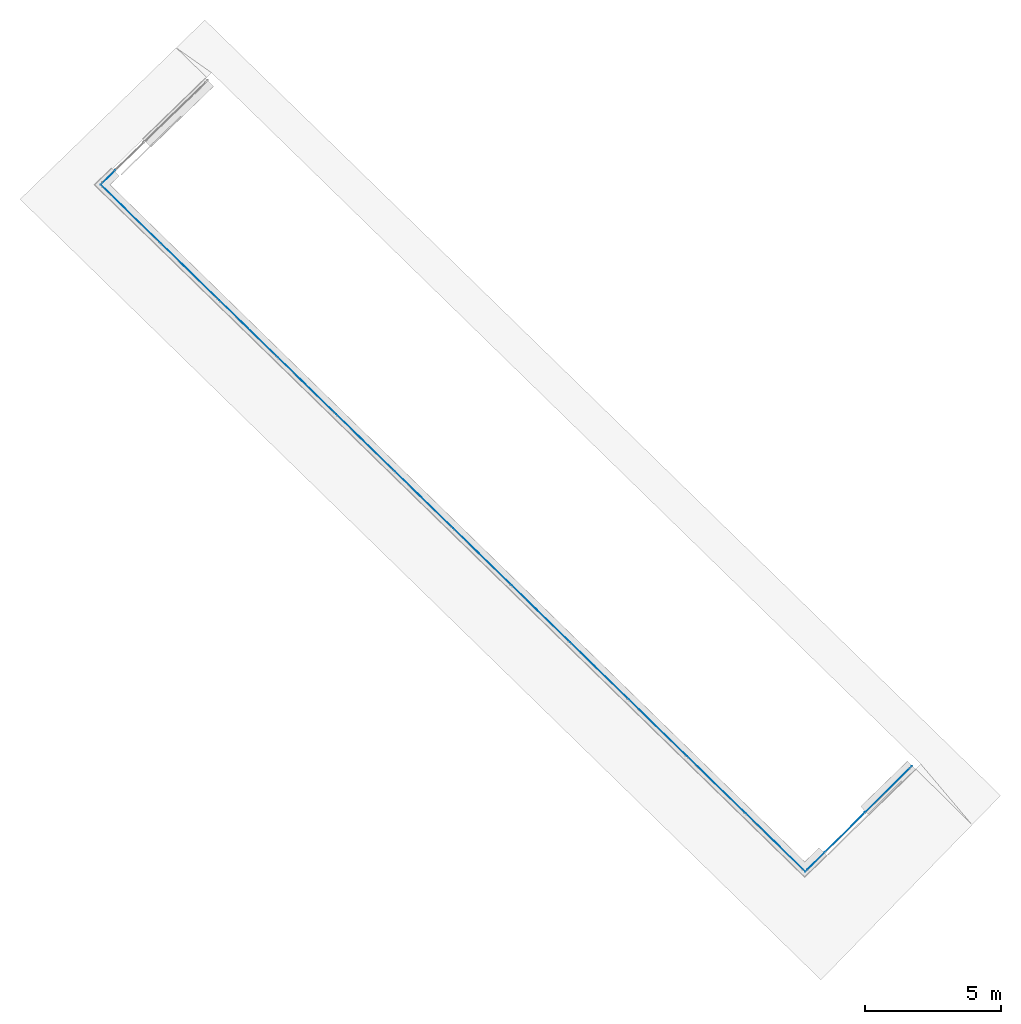
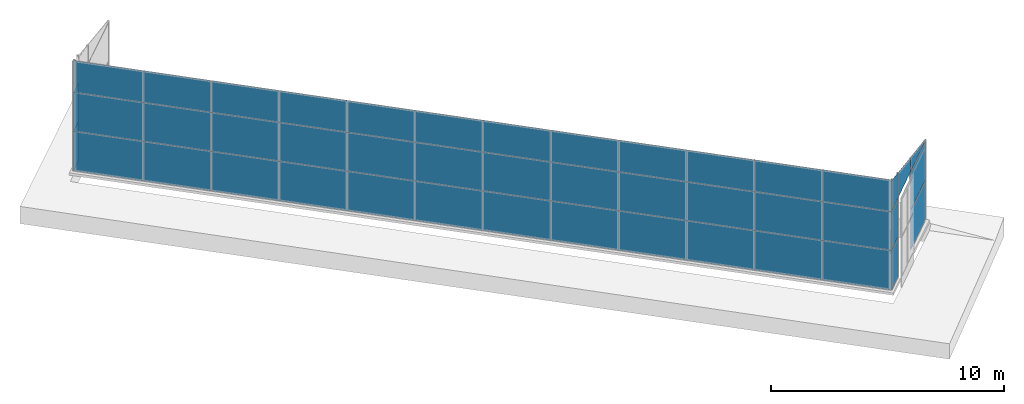
# One storey, part 9 of 13: 45 plates, 3 elements without a shape of their own.
"""IFC4 building model written with IfcOpenShell, lengths in metres."""

from ifc_helpers import new_model, entity, si_unit, converted_unit, direction, frame, origin, place, context, subcontext, project, spatial, indexed_curve, outline, extrude, source, transform, mapped, material, type_object, type_shapes, element, aggregate, save


model = new_model("IFC4")

# Units and contexts
model_context = context("Model", 3, precision=1e-05, world=origin(), true_north=direction((6.123233995736766e-17, 1.0)))
body_context = subcontext(model_context, "Body", "Model", "MODEL_VIEW")
ifc_project = project(units=[si_unit("LENGTHUNIT", "METRE"), si_unit("AREAUNIT", "SQUARE_METRE"), si_unit("VOLUMEUNIT", "CUBIC_METRE"), converted_unit("PLANEANGLEUNIT", "DEGREE", entity("IfcPlaneAngleMeasure", 0.017453292519943278), si_unit("PLANEANGLEUNIT", "RADIAN"), dimensions=[0, 0, 0, 0, 0, 0, 0])], contexts=[model_context])

# Site, building, storey
site_placement = place(None, frame((0.0, 0.0, 0.0), z_axis=(0.0, 0.0, 1.0), x_axis=(0.7160934825303189, -0.6980043870045516, 0.0)))
site = spatial("IfcSite", under=ifc_project, at=site_placement, CompositionType="ELEMENT")
building_placement = place(site_placement, origin())
building = spatial("IfcBuilding", under=site, at=building_placement, CompositionType="ELEMENT")
storey_placement = place(building_placement, frame((0.0, 0.0, -7.0)))
storey = spatial("IfcBuildingStorey", under=building, at=storey_placement, Name="-7.00 m", CompositionType="ELEMENT", Elevation=-7.000000000000001)

# Curtain wall, plates
curtain_wall_type_1 = type_object("IfcCurtainWallType", Name="Facciata continua:Vetrata_2", PredefinedType="NOTDEFINED")
curtain_wall_1_placement = place(storey_placement, frame((0.0, 0.0, 7.0)))
curtain_wall_1 = element("IfcCurtainWall", 1, at=curtain_wall_1_placement, inside=storey, type_object=curtain_wall_type_1, Name="Facciata continua:Vetrata_2", ObjectType="Facciata continua:Vetrata_2", PredefinedType="NOTDEFINED")
ifc_material = material(Name="Default - Vetro", Category="Vetro")
plate_type_1 = type_object("IfcPlateType", Name="Pannello sistema:Vetrato_fine", PredefinedType="CURTAIN_PANEL", material=ifc_material)
shared_shape_1 = source(origin(), body_context, "Body", "SweptSolid", [
    extrude(outline(indexed_curve([(-0.0025, -1.541372928393129), (0.0025, -1.541372928393129), (0.0025, 1.541372928393129), (-0.0025, 1.541372928393129), (-0.0025, -1.541372928393129)], self_intersect=False)), frame((0.0, 0.0, 0.0), z_axis=(0.0, 0.0, 1.0), x_axis=(0.0, 1.0, 0.0)), (0.0, 0.0, 1.0), 2.0800000000000005),
])
type_shapes(plate_type_1, [shared_shape_1])
plate_1_placement = place(curtain_wall_1_placement, frame((-26.27233328426332, -6.97785437653578, -6.94)))
plate_1 = element("IfcPlate", 2, at=plate_1_placement, type_object=plate_type_1, material=ifc_material, Name="Pannello sistema:Vetrato_fine", ObjectType="Pannello sistema:Vetrato_fine", PredefinedType="CURTAIN_PANEL", context=body_context, shape_type="MappedRepresentation", body=[
    mapped(shared_shape_1, transform((0.0, 0.0, 0.0), scale=1.0)),
])
plate_type_2 = type_object("IfcPlateType", Name="Pannello sistema:Vetrato_fine", PredefinedType="CURTAIN_PANEL", material=ifc_material)
shared_shape_2 = source(origin(), body_context, "Body", "SweptSolid", [
    extrude(outline(indexed_curve([(-0.0025, -1.500587508215072), (0.0025, -1.500587508215072), (0.0025, 1.500587508215072), (-0.0025, 1.500587508215072), (-0.0025, -1.500587508215072)], self_intersect=False)), frame((0.0, 0.0, 0.0), z_axis=(0.0, 0.0, 1.0), x_axis=(0.0, 1.0, 0.0)), (0.0, 0.0, 1.0), 2.0800000000000005),
])
type_shapes(plate_type_2, [shared_shape_2])
plate_2_placement = place(curtain_wall_1_placement, frame((-23.23037284765512, -6.977854376535789, -6.94)))
plate_2 = element("IfcPlate", 3, at=plate_2_placement, type_object=plate_type_2, material=ifc_material, Name="Pannello sistema:Vetrato_fine", ObjectType="Pannello sistema:Vetrato_fine", PredefinedType="CURTAIN_PANEL", context=body_context, shape_type="MappedRepresentation", body=[
    mapped(shared_shape_2, transform((0.0, 0.0, 0.0), scale=1.0)),
])
plate_3_placement = place(curtain_wall_1_placement, frame((-20.229197831224973, -6.977854376535799, -6.94)))
plate_3 = element("IfcPlate", 4, at=plate_3_placement, type_object=plate_type_2, material=ifc_material, Name="Pannello sistema:Vetrato_fine", ObjectType="Pannello sistema:Vetrato_fine", PredefinedType="CURTAIN_PANEL", context=body_context, shape_type="MappedRepresentation", body=[
    mapped(shared_shape_2, transform((0.0, 0.0, 0.0), scale=1.0)),
])
plate_4_placement = place(curtain_wall_1_placement, frame((-17.22802281479483, -6.9778543765358085, -6.94)))
plate_4 = element("IfcPlate", 5, at=plate_4_placement, type_object=plate_type_2, material=ifc_material, Name="Pannello sistema:Vetrato_fine", ObjectType="Pannello sistema:Vetrato_fine", PredefinedType="CURTAIN_PANEL", context=body_context, shape_type="MappedRepresentation", body=[
    mapped(shared_shape_2, transform((0.0, 0.0, 0.0), scale=1.0)),
])
plate_5_placement = place(curtain_wall_1_placement, frame((-14.226847798364687, -6.977854376535818, -6.94)))
plate_5 = element("IfcPlate", 6, at=plate_5_placement, type_object=plate_type_2, material=ifc_material, Name="Pannello sistema:Vetrato_fine", ObjectType="Pannello sistema:Vetrato_fine", PredefinedType="CURTAIN_PANEL", context=body_context, shape_type="MappedRepresentation", body=[
    mapped(shared_shape_2, transform((0.0, 0.0, 0.0), scale=1.0)),
])
plate_6_placement = place(curtain_wall_1_placement, frame((-11.225672781934538, -6.977854376535828, -6.94)))
plate_6 = element("IfcPlate", 7, at=plate_6_placement, type_object=plate_type_2, material=ifc_material, Name="Pannello sistema:Vetrato_fine", ObjectType="Pannello sistema:Vetrato_fine", PredefinedType="CURTAIN_PANEL", context=body_context, shape_type="MappedRepresentation", body=[
    mapped(shared_shape_2, transform((0.0, 0.0, 0.0), scale=1.0)),
])
plate_7_placement = place(curtain_wall_1_placement, frame((-8.22449776550439, -6.977854376535838, -6.94)))
plate_7 = element("IfcPlate", 8, at=plate_7_placement, type_object=plate_type_2, material=ifc_material, Name="Pannello sistema:Vetrato_fine", ObjectType="Pannello sistema:Vetrato_fine", PredefinedType="CURTAIN_PANEL", context=body_context, shape_type="MappedRepresentation", body=[
    mapped(shared_shape_2, transform((0.0, 0.0, 0.0), scale=1.0)),
])
plate_8_placement = place(curtain_wall_1_placement, frame((-5.223322749074251, -6.977854376535847, -6.94)))
plate_8 = element("IfcPlate", 9, at=plate_8_placement, type_object=plate_type_2, material=ifc_material, Name="Pannello sistema:Vetrato_fine", ObjectType="Pannello sistema:Vetrato_fine", PredefinedType="CURTAIN_PANEL", context=body_context, shape_type="MappedRepresentation", body=[
    mapped(shared_shape_2, transform((0.0, 0.0, 0.0), scale=1.0)),
])
plate_9_placement = place(curtain_wall_1_placement, frame((-2.2221477326441077, -6.9778543765358565, -6.94)))
plate_9 = element("IfcPlate", 10, at=plate_9_placement, type_object=plate_type_2, material=ifc_material, Name="Pannello sistema:Vetrato_fine", ObjectType="Pannello sistema:Vetrato_fine", PredefinedType="CURTAIN_PANEL", context=body_context, shape_type="MappedRepresentation", body=[
    mapped(shared_shape_2, transform((0.0, 0.0, 0.0), scale=1.0)),
])
plate_10_placement = place(curtain_wall_1_placement, frame((0.779027283786036, -6.977854376535866, -6.94)))
plate_10 = element("IfcPlate", 11, at=plate_10_placement, type_object=plate_type_2, material=ifc_material, Name="Pannello sistema:Vetrato_fine", ObjectType="Pannello sistema:Vetrato_fine", PredefinedType="CURTAIN_PANEL", context=body_context, shape_type="MappedRepresentation", body=[
    mapped(shared_shape_2, transform((0.0, 0.0, 0.0), scale=1.0)),
])
plate_11_placement = place(curtain_wall_1_placement, frame((3.7802023002161795, -6.977854376535876, -6.94)))
plate_11 = element("IfcPlate", 12, at=plate_11_placement, type_object=plate_type_2, material=ifc_material, Name="Pannello sistema:Vetrato_fine", ObjectType="Pannello sistema:Vetrato_fine", PredefinedType="CURTAIN_PANEL", context=body_context, shape_type="MappedRepresentation", body=[
    mapped(shared_shape_2, transform((0.0, 0.0, 0.0), scale=1.0)),
])
plate_type_3 = type_object("IfcPlateType", Name="Pannello sistema:Vetrato_fine", PredefinedType="CURTAIN_PANEL", material=ifc_material)
shared_shape_3 = source(origin(), body_context, "Body", "SweptSolid", [
    extrude(outline(indexed_curve([(-0.0025, -1.530587508215076), (0.0025, -1.530587508215076), (0.0025, 1.530587508215076), (-0.0025, 1.530587508215076), (-0.0025, -1.530587508215076)], self_intersect=False)), frame((0.0, 0.0, 0.0), z_axis=(0.0, 0.0, 1.0), x_axis=(0.0, 1.0, 0.0)), (0.0, 0.0, 1.0), 2.0800000000000005),
])
type_shapes(plate_type_3, [shared_shape_3])
plate_12_placement = place(curtain_wall_1_placement, frame((6.81137731664633, -6.977854376535886, -6.94)))
plate_12 = element("IfcPlate", 13, at=plate_12_placement, type_object=plate_type_3, material=ifc_material, Name="Pannello sistema:Vetrato_fine", ObjectType="Pannello sistema:Vetrato_fine", PredefinedType="CURTAIN_PANEL", context=body_context, shape_type="MappedRepresentation", body=[
    mapped(shared_shape_3, transform((0.0, 0.0, 0.0), scale=1.0)),
])
plate_type_4 = type_object("IfcPlateType", Name="Pannello sistema:Vetrato_fine", PredefinedType="CURTAIN_PANEL", material=ifc_material)
shared_shape_4 = source(origin(), body_context, "Body", "SweptSolid", [
    extrude(outline(indexed_curve([(-0.0025, -1.541372928393129), (0.0025, -1.541372928393129), (0.0025, 1.541372928393129), (-0.0025, 1.541372928393129), (-0.0025, -1.541372928393129)], self_intersect=False)), frame((0.0, 0.0, 0.0), z_axis=(0.0, 0.0, 1.0), x_axis=(0.0, 1.0, 0.0)), (0.0, 0.0, 1.0), 2.030000000000001),
])
type_shapes(plate_type_4, [shared_shape_4])
plate_13_placement = place(curtain_wall_1_placement, frame((-26.27233328426332, -6.97785437653578, -4.86)))
plate_13 = element("IfcPlate", 14, at=plate_13_placement, type_object=plate_type_4, material=ifc_material, Name="Pannello sistema:Vetrato_fine", ObjectType="Pannello sistema:Vetrato_fine", PredefinedType="CURTAIN_PANEL", context=body_context, shape_type="MappedRepresentation", body=[
    mapped(shared_shape_4, transform((0.0, 0.0, 0.0), scale=1.0)),
])
plate_type_5 = type_object("IfcPlateType", Name="Pannello sistema:Vetrato_fine", PredefinedType="CURTAIN_PANEL", material=ifc_material)
shared_shape_5 = source(origin(), body_context, "Body", "SweptSolid", [
    extrude(outline(indexed_curve([(-0.0025, -1.500587508215072), (0.0025, -1.500587508215072), (0.0025, 1.500587508215072), (-0.0025, 1.500587508215072), (-0.0025, -1.500587508215072)], self_intersect=False)), frame((0.0, 0.0, 0.0), z_axis=(0.0, 0.0, 1.0), x_axis=(0.0, 1.0, 0.0)), (0.0, 0.0, 1.0), 2.030000000000001),
])
type_shapes(plate_type_5, [shared_shape_5])
plate_14_placement = place(curtain_wall_1_placement, frame((-23.23037284765512, -6.977854376535789, -4.86)))
plate_14 = element("IfcPlate", 15, at=plate_14_placement, type_object=plate_type_5, material=ifc_material, Name="Pannello sistema:Vetrato_fine", ObjectType="Pannello sistema:Vetrato_fine", PredefinedType="CURTAIN_PANEL", context=body_context, shape_type="MappedRepresentation", body=[
    mapped(shared_shape_5, transform((0.0, 0.0, 0.0), scale=1.0)),
])
plate_15_placement = place(curtain_wall_1_placement, frame((-20.229197831224973, -6.977854376535799, -4.86)))
plate_15 = element("IfcPlate", 16, at=plate_15_placement, type_object=plate_type_5, material=ifc_material, Name="Pannello sistema:Vetrato_fine", ObjectType="Pannello sistema:Vetrato_fine", PredefinedType="CURTAIN_PANEL", context=body_context, shape_type="MappedRepresentation", body=[
    mapped(shared_shape_5, transform((0.0, 0.0, 0.0), scale=1.0)),
])
plate_16_placement = place(curtain_wall_1_placement, frame((-17.22802281479483, -6.9778543765358085, -4.86)))
plate_16 = element("IfcPlate", 17, at=plate_16_placement, type_object=plate_type_5, material=ifc_material, Name="Pannello sistema:Vetrato_fine", ObjectType="Pannello sistema:Vetrato_fine", PredefinedType="CURTAIN_PANEL", context=body_context, shape_type="MappedRepresentation", body=[
    mapped(shared_shape_5, transform((0.0, 0.0, 0.0), scale=1.0)),
])
plate_17_placement = place(curtain_wall_1_placement, frame((-14.226847798364687, -6.977854376535818, -4.86)))
plate_17 = element("IfcPlate", 18, at=plate_17_placement, type_object=plate_type_5, material=ifc_material, Name="Pannello sistema:Vetrato_fine", ObjectType="Pannello sistema:Vetrato_fine", PredefinedType="CURTAIN_PANEL", context=body_context, shape_type="MappedRepresentation", body=[
    mapped(shared_shape_5, transform((0.0, 0.0, 0.0), scale=1.0)),
])
plate_18_placement = place(curtain_wall_1_placement, frame((-11.225672781934538, -6.977854376535828, -4.86)))
plate_18 = element("IfcPlate", 19, at=plate_18_placement, type_object=plate_type_5, material=ifc_material, Name="Pannello sistema:Vetrato_fine", ObjectType="Pannello sistema:Vetrato_fine", PredefinedType="CURTAIN_PANEL", context=body_context, shape_type="MappedRepresentation", body=[
    mapped(shared_shape_5, transform((0.0, 0.0, 0.0), scale=1.0)),
])
plate_19_placement = place(curtain_wall_1_placement, frame((-8.22449776550439, -6.977854376535838, -4.86)))
plate_19 = element("IfcPlate", 20, at=plate_19_placement, type_object=plate_type_5, material=ifc_material, Name="Pannello sistema:Vetrato_fine", ObjectType="Pannello sistema:Vetrato_fine", PredefinedType="CURTAIN_PANEL", context=body_context, shape_type="MappedRepresentation", body=[
    mapped(shared_shape_5, transform((0.0, 0.0, 0.0), scale=1.0)),
])
plate_20_placement = place(curtain_wall_1_placement, frame((-5.223322749074251, -6.977854376535847, -4.86)))
plate_20 = element("IfcPlate", 21, at=plate_20_placement, type_object=plate_type_5, material=ifc_material, Name="Pannello sistema:Vetrato_fine", ObjectType="Pannello sistema:Vetrato_fine", PredefinedType="CURTAIN_PANEL", context=body_context, shape_type="MappedRepresentation", body=[
    mapped(shared_shape_5, transform((0.0, 0.0, 0.0), scale=1.0)),
])
plate_21_placement = place(curtain_wall_1_placement, frame((-2.2221477326441077, -6.9778543765358565, -4.86)))
plate_21 = element("IfcPlate", 22, at=plate_21_placement, type_object=plate_type_5, material=ifc_material, Name="Pannello sistema:Vetrato_fine", ObjectType="Pannello sistema:Vetrato_fine", PredefinedType="CURTAIN_PANEL", context=body_context, shape_type="MappedRepresentation", body=[
    mapped(shared_shape_5, transform((0.0, 0.0, 0.0), scale=1.0)),
])
plate_22_placement = place(curtain_wall_1_placement, frame((0.779027283786036, -6.977854376535866, -4.86)))
plate_22 = element("IfcPlate", 23, at=plate_22_placement, type_object=plate_type_5, material=ifc_material, Name="Pannello sistema:Vetrato_fine", ObjectType="Pannello sistema:Vetrato_fine", PredefinedType="CURTAIN_PANEL", context=body_context, shape_type="MappedRepresentation", body=[
    mapped(shared_shape_5, transform((0.0, 0.0, 0.0), scale=1.0)),
])
plate_23_placement = place(curtain_wall_1_placement, frame((3.7802023002161795, -6.977854376535876, -4.86)))
plate_23 = element("IfcPlate", 24, at=plate_23_placement, type_object=plate_type_5, material=ifc_material, Name="Pannello sistema:Vetrato_fine", ObjectType="Pannello sistema:Vetrato_fine", PredefinedType="CURTAIN_PANEL", context=body_context, shape_type="MappedRepresentation", body=[
    mapped(shared_shape_5, transform((0.0, 0.0, 0.0), scale=1.0)),
])
plate_type_6 = type_object("IfcPlateType", Name="Pannello sistema:Vetrato_fine", PredefinedType="CURTAIN_PANEL", material=ifc_material)
shared_shape_6 = source(origin(), body_context, "Body", "SweptSolid", [
    extrude(outline(indexed_curve([(-0.0025, -1.5305875082150737), (0.0025, -1.5305875082150737), (0.0025, 1.5305875082150737), (-0.0025, 1.5305875082150737), (-0.0025, -1.5305875082150737)], self_intersect=False)), frame((0.0, 0.0, 0.0), z_axis=(0.0, 0.0, 1.0), x_axis=(0.0, 1.0, 0.0)), (0.0, 0.0, 1.0), 2.030000000000001),
])
type_shapes(plate_type_6, [shared_shape_6])
plate_24_placement = place(curtain_wall_1_placement, frame((6.811377316646325, -6.977854376535886, -4.86)))
plate_24 = element("IfcPlate", 25, at=plate_24_placement, type_object=plate_type_6, material=ifc_material, Name="Pannello sistema:Vetrato_fine", ObjectType="Pannello sistema:Vetrato_fine", PredefinedType="CURTAIN_PANEL", context=body_context, shape_type="MappedRepresentation", body=[
    mapped(shared_shape_6, transform((0.0, 0.0, 0.0), scale=1.0)),
])
plate_type_7 = type_object("IfcPlateType", Name="Pannello sistema:Vetrato_fine", PredefinedType="CURTAIN_PANEL", material=ifc_material)
shared_shape_7 = source(origin(), body_context, "Body", "SweptSolid", [
    extrude(outline(indexed_curve([(-0.0025, -1.541372928393129), (0.0025, -1.541372928393129), (0.0025, 1.541372928393129), (-0.0025, 1.541372928393129), (-0.0025, -1.541372928393129)], self_intersect=False)), frame((0.0, 0.0, 0.0), z_axis=(0.0, 0.0, 1.0), x_axis=(0.0, 1.0, 0.0)), (0.0, 0.0, 1.0), 1.6699999999999993),
])
type_shapes(plate_type_7, [shared_shape_7])
plate_25_placement = place(curtain_wall_1_placement, frame((-26.27233328426332, -6.97785437653578, -2.829999999999999)))
plate_25 = element("IfcPlate", 26, at=plate_25_placement, type_object=plate_type_7, material=ifc_material, Name="Pannello sistema:Vetrato_fine", ObjectType="Pannello sistema:Vetrato_fine", PredefinedType="CURTAIN_PANEL", context=body_context, shape_type="MappedRepresentation", body=[
    mapped(shared_shape_7, transform((0.0, 0.0, 0.0), scale=1.0)),
])
plate_type_8 = type_object("IfcPlateType", Name="Pannello sistema:Vetrato_fine", PredefinedType="CURTAIN_PANEL", material=ifc_material)
shared_shape_8 = source(origin(), body_context, "Body", "SweptSolid", [
    extrude(outline(indexed_curve([(-0.0025, -1.500587508215072), (0.0025, -1.500587508215072), (0.0025, 1.500587508215072), (-0.0025, 1.500587508215072), (-0.0025, -1.500587508215072)], self_intersect=False)), frame((0.0, 0.0, 0.0), z_axis=(0.0, 0.0, 1.0), x_axis=(0.0, 1.0, 0.0)), (0.0, 0.0, 1.0), 1.6699999999999993),
])
type_shapes(plate_type_8, [shared_shape_8])
plate_26_placement = place(curtain_wall_1_placement, frame((-23.23037284765512, -6.977854376535789, -2.829999999999999)))
plate_26 = element("IfcPlate", 27, at=plate_26_placement, type_object=plate_type_8, material=ifc_material, Name="Pannello sistema:Vetrato_fine", ObjectType="Pannello sistema:Vetrato_fine", PredefinedType="CURTAIN_PANEL", context=body_context, shape_type="MappedRepresentation", body=[
    mapped(shared_shape_8, transform((0.0, 0.0, 0.0), scale=1.0)),
])
plate_27_placement = place(curtain_wall_1_placement, frame((-20.229197831224973, -6.977854376535799, -2.829999999999999)))
plate_27 = element("IfcPlate", 28, at=plate_27_placement, type_object=plate_type_8, material=ifc_material, Name="Pannello sistema:Vetrato_fine", ObjectType="Pannello sistema:Vetrato_fine", PredefinedType="CURTAIN_PANEL", context=body_context, shape_type="MappedRepresentation", body=[
    mapped(shared_shape_8, transform((0.0, 0.0, 0.0), scale=1.0)),
])
plate_28_placement = place(curtain_wall_1_placement, frame((-17.22802281479483, -6.9778543765358085, -2.829999999999999)))
plate_28 = element("IfcPlate", 29, at=plate_28_placement, type_object=plate_type_8, material=ifc_material, Name="Pannello sistema:Vetrato_fine", ObjectType="Pannello sistema:Vetrato_fine", PredefinedType="CURTAIN_PANEL", context=body_context, shape_type="MappedRepresentation", body=[
    mapped(shared_shape_8, transform((0.0, 0.0, 0.0), scale=1.0)),
])
plate_29_placement = place(curtain_wall_1_placement, frame((-14.226847798364687, -6.977854376535818, -2.829999999999999)))
plate_29 = element("IfcPlate", 30, at=plate_29_placement, type_object=plate_type_8, material=ifc_material, Name="Pannello sistema:Vetrato_fine", ObjectType="Pannello sistema:Vetrato_fine", PredefinedType="CURTAIN_PANEL", context=body_context, shape_type="MappedRepresentation", body=[
    mapped(shared_shape_8, transform((0.0, 0.0, 0.0), scale=1.0)),
])
plate_30_placement = place(curtain_wall_1_placement, frame((-11.225672781934538, -6.977854376535828, -2.829999999999999)))
plate_30 = element("IfcPlate", 31, at=plate_30_placement, type_object=plate_type_8, material=ifc_material, Name="Pannello sistema:Vetrato_fine", ObjectType="Pannello sistema:Vetrato_fine", PredefinedType="CURTAIN_PANEL", context=body_context, shape_type="MappedRepresentation", body=[
    mapped(shared_shape_8, transform((0.0, 0.0, 0.0), scale=1.0)),
])
plate_31_placement = place(curtain_wall_1_placement, frame((-8.22449776550439, -6.977854376535838, -2.829999999999999)))
plate_31 = element("IfcPlate", 32, at=plate_31_placement, type_object=plate_type_8, material=ifc_material, Name="Pannello sistema:Vetrato_fine", ObjectType="Pannello sistema:Vetrato_fine", PredefinedType="CURTAIN_PANEL", context=body_context, shape_type="MappedRepresentation", body=[
    mapped(shared_shape_8, transform((0.0, 0.0, 0.0), scale=1.0)),
])
plate_32_placement = place(curtain_wall_1_placement, frame((-5.223322749074251, -6.977854376535847, -2.829999999999999)))
plate_32 = element("IfcPlate", 33, at=plate_32_placement, type_object=plate_type_8, material=ifc_material, Name="Pannello sistema:Vetrato_fine", ObjectType="Pannello sistema:Vetrato_fine", PredefinedType="CURTAIN_PANEL", context=body_context, shape_type="MappedRepresentation", body=[
    mapped(shared_shape_8, transform((0.0, 0.0, 0.0), scale=1.0)),
])
plate_33_placement = place(curtain_wall_1_placement, frame((-2.2221477326441077, -6.9778543765358565, -2.829999999999999)))
plate_33 = element("IfcPlate", 34, at=plate_33_placement, type_object=plate_type_8, material=ifc_material, Name="Pannello sistema:Vetrato_fine", ObjectType="Pannello sistema:Vetrato_fine", PredefinedType="CURTAIN_PANEL", context=body_context, shape_type="MappedRepresentation", body=[
    mapped(shared_shape_8, transform((0.0, 0.0, 0.0), scale=1.0)),
])
plate_34_placement = place(curtain_wall_1_placement, frame((0.779027283786036, -6.977854376535866, -2.829999999999999)))
plate_34 = element("IfcPlate", 35, at=plate_34_placement, type_object=plate_type_8, material=ifc_material, Name="Pannello sistema:Vetrato_fine", ObjectType="Pannello sistema:Vetrato_fine", PredefinedType="CURTAIN_PANEL", context=body_context, shape_type="MappedRepresentation", body=[
    mapped(shared_shape_8, transform((0.0, 0.0, 0.0), scale=1.0)),
])
plate_35_placement = place(curtain_wall_1_placement, frame((3.7802023002161795, -6.977854376535876, -2.829999999999999)))
plate_35 = element("IfcPlate", 36, at=plate_35_placement, type_object=plate_type_8, material=ifc_material, Name="Pannello sistema:Vetrato_fine", ObjectType="Pannello sistema:Vetrato_fine", PredefinedType="CURTAIN_PANEL", context=body_context, shape_type="MappedRepresentation", body=[
    mapped(shared_shape_8, transform((0.0, 0.0, 0.0), scale=1.0)),
])
plate_type_9 = type_object("IfcPlateType", Name="Pannello sistema:Vetrato_fine", PredefinedType="CURTAIN_PANEL", material=ifc_material)
shared_shape_9 = source(origin(), body_context, "Body", "SweptSolid", [
    extrude(outline(indexed_curve([(-0.0025, -1.5305875082150737), (0.0025, -1.5305875082150737), (0.0025, 1.5305875082150737), (-0.0025, 1.5305875082150737), (-0.0025, -1.5305875082150737)], self_intersect=False)), frame((0.0, 0.0, 0.0), z_axis=(0.0, 0.0, 1.0), x_axis=(0.0, 1.0, 0.0)), (0.0, 0.0, 1.0), 1.6699999999999993),
])
type_shapes(plate_type_9, [shared_shape_9])
plate_36_placement = place(curtain_wall_1_placement, frame((6.811377316646325, -6.977854376535886, -2.829999999999999)))
plate_36 = element("IfcPlate", 37, at=plate_36_placement, type_object=plate_type_9, material=ifc_material, Name="Pannello sistema:Vetrato_fine", ObjectType="Pannello sistema:Vetrato_fine", PredefinedType="CURTAIN_PANEL", context=body_context, shape_type="MappedRepresentation", body=[
    mapped(shared_shape_9, transform((0.0, 0.0, 0.0), scale=1.0)),
])
aggregate(curtain_wall_1, [plate_1, plate_2, plate_3, plate_4, plate_5, plate_6, plate_7, plate_8, plate_9, plate_10, plate_11, plate_12, plate_13, plate_14, plate_15, plate_16, plate_17, plate_18, plate_19, plate_20, plate_21, plate_22, plate_23, plate_24, plate_25, plate_26, plate_27, plate_28, plate_29, plate_30, plate_31, plate_32, plate_33, plate_34, plate_35, plate_36])

curtain_wall_type_2 = type_object("IfcCurtainWallType", Name="Facciata continua:Vetrata_1", PredefinedType="NOTDEFINED")
curtain_wall_2_placement = place(storey_placement, frame((0.0, 0.0, 7.0)))
curtain_wall_2 = element("IfcCurtainWall", 38, at=curtain_wall_2_placement, inside=storey, type_object=curtain_wall_type_2, Name="Facciata continua:Vetrata_1", ObjectType="Facciata continua:Vetrata_1", PredefinedType="NOTDEFINED")
plate_type_10 = type_object("IfcPlateType", Name="Pannello sistema:Vetrato_fine", PredefinedType="CURTAIN_PANEL", material=ifc_material)
shared_shape_10 = source(origin(), body_context, "Body", "SweptSolid", [
    extrude(outline(indexed_curve([(-0.0025, -0.5028489241452144), (0.0025, -0.5028489241452144), (0.0025, 0.5028489241452144), (-0.0025, 0.5028489241452144), (-0.0025, -0.5028489241452144)], self_intersect=False)), frame((0.0, 0.0, 0.0), z_axis=(0.0, 0.0, 1.0), x_axis=(0.0, 1.0, 0.0)), (0.0, 0.0, 1.0), 2.0800000000000005),
])
type_shapes(plate_type_10, [shared_shape_10])
plate_37_placement = place(curtain_wall_2_placement, frame((8.350833160124862, -6.475083660260913, -6.94), z_axis=(0.0, 0.0, 1.0), x_axis=(0.017636182236115534, 0.9998444704433458, 0.0)))
plate_37 = element("IfcPlate", 39, at=plate_37_placement, type_object=plate_type_10, material=ifc_material, Name="Pannello sistema:Vetrato_fine", ObjectType="Pannello sistema:Vetrato_fine", PredefinedType="CURTAIN_PANEL", context=body_context, shape_type="MappedRepresentation", body=[
    mapped(shared_shape_10, transform((0.0, 0.0, 0.0), scale=1.0)),
])
plate_type_11 = type_object("IfcPlateType", Name="Pannello sistema:Vetrato_fine", PredefinedType="CURTAIN_PANEL", material=ifc_material)
shared_shape_11 = source(origin(), body_context, "Body", "SweptSolid", [
    extrude(outline(indexed_curve([(-0.0025, -1.2125762929908375), (0.0025, -1.2125762929908375), (0.0025, 1.2125762929908375), (-0.0025, 1.2125762929908375), (-0.0025, -1.2125762929908375)], self_intersect=False)), frame((0.0, 0.0, 0.0), z_axis=(0.0, 0.0, 1.0), x_axis=(0.0, 1.0, 0.0)), (0.0, 0.0, 1.0), 2.0800000000000005),
])
type_shapes(plate_type_11, [shared_shape_11])
plate_38_placement = place(curtain_wall_2_placement, frame((8.417713793361655, -2.683433606621964, -6.94), z_axis=(0.0, 0.0, 1.0), x_axis=(0.017636182236115534, 0.9998444704433458, 0.0)))
plate_38 = element("IfcPlate", 40, at=plate_38_placement, type_object=plate_type_11, material=ifc_material, Name="Pannello sistema:Vetrato_fine", ObjectType="Pannello sistema:Vetrato_fine", PredefinedType="CURTAIN_PANEL", context=body_context, shape_type="MappedRepresentation", body=[
    mapped(shared_shape_11, transform((0.0, 0.0, 0.0), scale=1.0)),
])
plate_type_12 = type_object("IfcPlateType", Name="Pannello sistema:Vetrato_fine", PredefinedType="CURTAIN_PANEL", material=ifc_material)
shared_shape_12 = source(origin(), body_context, "Body", "SweptSolid", [
    extrude(outline(indexed_curve([(-0.0025, -0.5028489241452144), (0.0025, -0.5028489241452144), (0.0025, 0.5028489241452144), (-0.0025, 0.5028489241452144), (-0.0025, -0.5028489241452144)], self_intersect=False)), frame((0.0, 0.0, 0.0), z_axis=(0.0, 0.0, 1.0), x_axis=(0.0, 1.0, 0.0)), (0.0, 0.0, 1.0), 2.030000000000001),
])
type_shapes(plate_type_12, [shared_shape_12])
plate_39_placement = place(curtain_wall_2_placement, frame((8.350833160124862, -6.475083660260913, -4.86), z_axis=(0.0, 0.0, 1.0), x_axis=(0.017636182236115534, 0.9998444704433458, 0.0)))
plate_39 = element("IfcPlate", 41, at=plate_39_placement, type_object=plate_type_12, material=ifc_material, Name="Pannello sistema:Vetrato_fine", ObjectType="Pannello sistema:Vetrato_fine", PredefinedType="CURTAIN_PANEL", context=body_context, shape_type="MappedRepresentation", body=[
    mapped(shared_shape_12, transform((0.0, 0.0, 0.0), scale=1.0)),
])
plate_type_13 = type_object("IfcPlateType", Name="Pannello sistema:Vetrato_fine", PredefinedType="CURTAIN_PANEL", material=ifc_material)
shared_shape_13 = source(origin(), body_context, "Body", "SweptSolid", [
    extrude(outline(indexed_curve([(-0.0025, -1.2125762929908375), (0.0025, -1.2125762929908375), (0.0025, 1.2125762929908375), (-0.0025, 1.2125762929908375), (-0.0025, -1.2125762929908375)], self_intersect=False)), frame((0.0, 0.0, 0.0), z_axis=(0.0, 0.0, 1.0), x_axis=(0.0, 1.0, 0.0)), (0.0, 0.0, 1.0), 2.030000000000001),
])
type_shapes(plate_type_13, [shared_shape_13])
plate_40_placement = place(curtain_wall_2_placement, frame((8.417713793361655, -2.683433606621964, -4.86), z_axis=(0.0, 0.0, 1.0), x_axis=(0.017636182236115534, 0.9998444704433458, 0.0)))
plate_40 = element("IfcPlate", 42, at=plate_40_placement, type_object=plate_type_13, material=ifc_material, Name="Pannello sistema:Vetrato_fine", ObjectType="Pannello sistema:Vetrato_fine", PredefinedType="CURTAIN_PANEL", context=body_context, shape_type="MappedRepresentation", body=[
    mapped(shared_shape_13, transform((0.0, 0.0, 0.0), scale=1.0)),
])
plate_type_14 = type_object("IfcPlateType", Name="Pannello sistema:Vetrato_fine", PredefinedType="CURTAIN_PANEL", material=ifc_material)
shared_shape_14 = source(origin(), body_context, "Body", "SweptSolid", [
    extrude(outline(indexed_curve([(-0.9029179157321354, -0.42023724237480276), (0.6870820842678648, -0.42023724237480276), (0.6870820842678713, -0.33044672708164685), (0.43167166292853454, 0.5854606059156261), (-0.9029179157321354, 0.5854606059156261), (-0.9029179157321354, -0.42023724237480276)], self_intersect=False)), frame((-0.08261168177041169, -0.0025000000000009476, 0.9029179157321354), z_axis=(0.0, 1.0, 0.0), x_axis=(0.0, 0.0, 1.0)), (0.0, 0.0, 1.0), 0.005),
])
type_shapes(plate_type_14, [shared_shape_14])
plate_41_placement = place(curtain_wall_2_placement, frame((8.350833160124862, -6.475083660260913, -2.829999999999999), z_axis=(0.0, 0.0, 1.0), x_axis=(0.017636182236115534, 0.9998444704433458, 0.0)))
plate_41 = element("IfcPlate", 43, at=plate_41_placement, type_object=plate_type_14, material=ifc_material, Name="Pannello sistema:Vetrato_fine", ObjectType="Pannello sistema:Vetrato_fine", PredefinedType="CURTAIN_PANEL", context=body_context, shape_type="MappedRepresentation", body=[
    mapped(shared_shape_14, transform((0.0, 0.0, 0.0), scale=1.0)),
])
plate_type_15 = type_object("IfcPlateType", Name="Pannello sistema:Vetrato_fine", PredefinedType="CURTAIN_PANEL", material=ifc_material)
shared_shape_15 = source(origin(), body_context, "Body", "SweptSolid", [
    extrude(outline(indexed_curve([(-0.522509371740056, -1.0384073209434481), (0.8120802069206141, -1.0384073209434488), (0.23293853655949776, 1.0384073209434481), (-0.522509371740056, 1.0384073209434488), (-0.522509371740056, -1.0384073209434481)], self_intersect=False)), frame((0.0, -0.0024999999999999155, 0.522509371740056), z_axis=(0.0, 1.0, 0.0), x_axis=(0.0, 0.0, 1.0)), (0.0, 0.0, 1.0), 0.005),
])
type_shapes(plate_type_15, [shared_shape_15])
plate_42_placement = place(curtain_wall_2_placement, frame((8.378015036135798, -4.934067126072739, -2.829999999999999), z_axis=(0.0, 0.0, 1.0), x_axis=(0.017636182236115534, 0.9998444704433458, 0.0)))
plate_42 = element("IfcPlate", 44, at=plate_42_placement, type_object=plate_type_15, material=ifc_material, Name="Pannello sistema:Vetrato_fine", ObjectType="Pannello sistema:Vetrato_fine", PredefinedType="CURTAIN_PANEL", context=body_context, shape_type="MappedRepresentation", body=[
    mapped(shared_shape_15, transform((0.0, 0.0, 0.0), scale=1.0)),
])
plate_type_16 = type_object("IfcPlateType", Name="Pannello sistema:Vetrato_fine", PredefinedType="CURTAIN_PANEL", material=ifc_material)
shared_shape_16 = source(origin(), body_context, "Body", "SweptSolid", [
    extrude(outline(indexed_curve([(-0.2086541090130511, -1.2125762929908375), (0.5467937992865026, -1.2125762929908375), (-0.12948558126040036, 1.2125762929908375), (-0.2086541090130511, 1.2125762929908375), (-0.2086541090130511, -1.2125762929908375)], self_intersect=False)), frame((0.0, -0.002499999999999839, 0.2086541090130511), z_axis=(0.0, 1.0, 0.0), x_axis=(0.0, 0.0, 1.0)), (0.0, 0.0, 1.0), 0.005),
])
type_shapes(plate_type_16, [shared_shape_16])
plate_43_placement = place(curtain_wall_2_placement, frame((8.417713793361655, -2.683433606621964, -2.829999999999999), z_axis=(0.0, 0.0, 1.0), x_axis=(0.017636182236115534, 0.9998444704433458, 0.0)))
plate_43 = element("IfcPlate", 45, at=plate_43_placement, type_object=plate_type_16, material=ifc_material, Name="Pannello sistema:Vetrato_fine", ObjectType="Pannello sistema:Vetrato_fine", PredefinedType="CURTAIN_PANEL", context=body_context, shape_type="MappedRepresentation", body=[
    mapped(shared_shape_16, transform((0.0, 0.0, 0.0), scale=1.0)),
])
aggregate(curtain_wall_2, [plate_37, plate_38, plate_39, plate_40, plate_41, plate_42, plate_43])

curtain_wall_3_placement = place(storey_placement, frame((0.0, 0.0, 7.0)))
curtain_wall_3 = element("IfcCurtainWall", 46, at=curtain_wall_3_placement, inside=storey, type_object=curtain_wall_type_2, Name="Facciata continua:Vetrata_1", ObjectType="Facciata continua:Vetrata_1", PredefinedType="NOTDEFINED")
plate_type_17 = type_object("IfcPlateType", Name="Pannello sistema:Vetrato_fine", PredefinedType="CURTAIN_PANEL", material=ifc_material)
shared_shape_17 = source(origin(), body_context, "Body", "SweptSolid", [
    extrude(outline(indexed_curve([(-0.0025, -0.3784875870983653), (0.0025, -0.3784875870983653), (0.0025, 0.37848758709836544), (-0.0025, 0.37848758709836544), (-0.0025, -0.3784875870983653)], self_intersect=False)), frame((0.0, 0.0, 0.0), z_axis=(0.0, 0.0, 1.0), x_axis=(0.0, 1.0, 0.0)), (0.0, 0.0, 1.0), 2.079999999999999),
])
type_shapes(plate_type_17, [shared_shape_17])
plate_44_placement = place(curtain_wall_3_placement, frame((-27.803116103552533, -6.599514974441955, -6.9399999999999995), z_axis=(0.0, 0.0, 1.0), x_axis=(-0.027980069795956325, -0.9996084812036228, 0.0)))
plate_44 = element("IfcPlate", 47, at=plate_44_placement, type_object=plate_type_17, material=ifc_material, Name="Pannello sistema:Vetrato_fine", ObjectType="Pannello sistema:Vetrato_fine", PredefinedType="CURTAIN_PANEL", context=body_context, shape_type="MappedRepresentation", body=[
    mapped(shared_shape_17, transform((0.0, 0.0, 0.0), scale=1.0)),
])
plate_type_18 = type_object("IfcPlateType", Name="Pannello sistema:Vetrato_fine", PredefinedType="CURTAIN_PANEL", material=ifc_material)
shared_shape_18 = source(origin(), body_context, "Body", "SweptSolid", [
    extrude(outline(indexed_curve([(-0.0025, -0.3784875870983648), (0.0025, -0.3784875870983648), (0.0025, 0.3784875870983649), (-0.0025, 0.3784875870983649), (-0.0025, -0.3784875870983648)], self_intersect=False)), frame((0.0, 0.0, 0.0), z_axis=(0.0, 0.0, 1.0), x_axis=(0.0, 1.0, 0.0)), (0.0, 0.0, 1.0), 2.030000000000001),
])
type_shapes(plate_type_18, [shared_shape_18])
plate_45_placement = place(curtain_wall_3_placement, frame((-27.803116103552533, -6.599514974441955, -4.86), z_axis=(0.0, 0.0, 1.0), x_axis=(-0.027980069795956325, -0.9996084812036228, 0.0)))
plate_45 = element("IfcPlate", 48, at=plate_45_placement, type_object=plate_type_18, material=ifc_material, Name="Pannello sistema:Vetrato_fine", ObjectType="Pannello sistema:Vetrato_fine", PredefinedType="CURTAIN_PANEL", context=body_context, shape_type="MappedRepresentation", body=[
    mapped(shared_shape_18, transform((0.0, 0.0, 0.0), scale=1.0)),
])
aggregate(curtain_wall_3, [plate_44, plate_45])

save(model, "model.ifc")
